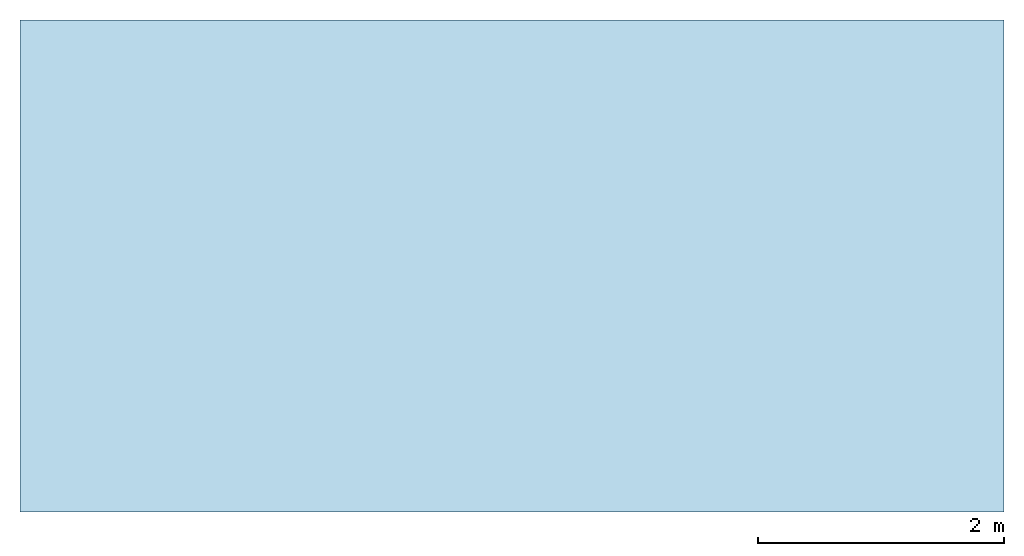
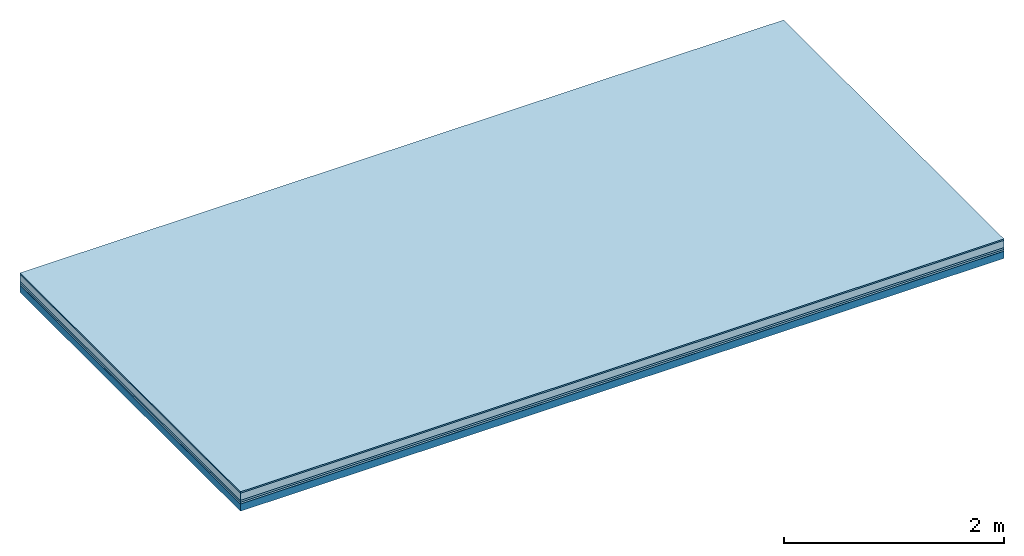
# One storey: 5 plates, 1 member, 1 element without a shape of its own.
"""IFC4 building model written with IfcOpenShell, lengths in metres."""

from ifc_helpers import new_model, si_unit, derived_unit, direction, frame, frame_2d, origin, origin_with_axes, place, context, project, spatial, rectangle, extrude, material, layer, layer_set, type_object, element, aggregate, save


model = new_model("IFC4")

# Units and contexts
plan_context = context("Plan", 3, precision=1e-05, world=origin(), true_north=direction((0.0, 1.0)))
model_context = context("Model", 3, precision=1e-05, world=origin(), true_north=direction((0.0, 1.0)))
ifc_project = project(units=[si_unit("LENGTHUNIT", "METRE"), derived_unit("SOUNDPRESSUREUNIT", [(si_unit("PRESSUREUNIT", "PASCAL", prefix="MICRO"), 0)]), si_unit("ENERGYUNIT", "JOULE", prefix="MEGA"), si_unit("MASSUNIT", "GRAM", prefix="KILO"), derived_unit("THERMALTRANSMITTANCEUNIT", [(si_unit("POWERUNIT", "WATT"), 1), (si_unit("AREAUNIT", "SQUARE_METRE"), -1), (si_unit("THERMODYNAMICTEMPERATUREUNIT", "KELVIN"), -1)]), derived_unit("AREADENSITYUNIT", [(si_unit("MASSUNIT", "GRAM", prefix="KILO"), 1), (si_unit("AREAUNIT", "SQUARE_METRE"), -1)]), derived_unit("USERDEFINED", [(si_unit("ENERGYUNIT", "JOULE", prefix="MEGA"), 1), (si_unit("AREAUNIT", "SQUARE_METRE"), -1)])], contexts=[plan_context, model_context])

# Site, building, storey
site = spatial("IfcSite", under=ifc_project)
building_placement = place(None, origin())
building = spatial("IfcBuilding", under=site, at=building_placement)
storey_placement = place(building_placement, origin())
storey = spatial("IfcBuildingStorey", under=building, at=storey_placement)

# Slab, member, plates
ifc_material_1 = material(Category="11.013")
ifc_layer_1 = layer(ifc_material_1, 0.015, Name="Flooring")
ifc_material_2 = material(Name="Cement screed", Category="04.006")
ifc_layer_2 = layer(ifc_material_2, 0.08, Name="On-material")
ifc_material_3 = material(Name="Wood fiber generic product", Category="10.009")
ifc_layer_3 = layer(ifc_material_3, 0.02, Name="Impact sound insulation")
ifc_material_4 = material()
ifc_layer_4 = layer(ifc_material_4, 0.02, Name="Additional insulation")
ifc_material_5 = material(Name="protection", Category="09.007")
ifc_layer_5 = layer(ifc_material_5, 0.0005, Name="Sub-floor")
ifc_material_6 = material(Name="no composite action")
ifc_layer_6 = layer(ifc_material_6, 0.0, Name="Bond")
ifc_layer_7 = layer(None, 0.08, Name="Supporting structure")
ifc_layer_set = layer_set([ifc_layer_1, ifc_layer_2, ifc_layer_3, ifc_layer_4, ifc_layer_5, ifc_layer_6, ifc_layer_7])
slab_type = type_object("IfcSlabType", Name="A2067", PredefinedType="NOTDEFINED", material=ifc_layer_set)
slab_placement = place(None, frame((0.0, 0.0, 0.0), z_axis=(0.0, 0.0, -1.0), x_axis=(1.0, 0.0, 0.0)))
slab = element("IfcSlab", 1, at=slab_placement, inside=storey, type_object=slab_type, material=ifc_layer_set, Name="Slab #1")
ifc_material_7 = material(Name="Solid timber panel")
member_placement = place(slab_placement, origin())
member = element("IfcMember", 2, at=member_placement, material=ifc_material_7, Name="Supporting structure", context=plan_context, shape_type="SweptSolid", body=[
    extrude(rectangle(XDim=1.0, YDim=0.08, at=frame_2d((0.5, 0.04), x_axis=(1.0, 0.0))), frame((0.0, 4.0, 0.1355), z_axis=(0.0, -1.0, 0.0), x_axis=(1.0, 0.0, 0.0)), (0.0, 0.0, 1.0), 4.0),
    extrude(rectangle(XDim=1.0, YDim=0.08, at=frame_2d((0.5, 0.04), x_axis=(1.0, 0.0))), frame((1.0, 4.0, 0.1355), z_axis=(0.0, -1.0, 0.0), x_axis=(1.0, 0.0, 0.0)), (0.0, 0.0, 1.0), 4.0),
    extrude(rectangle(XDim=1.0, YDim=0.08, at=frame_2d((0.5, 0.04), x_axis=(1.0, 0.0))), frame((2.0, 4.0, 0.1355), z_axis=(0.0, -1.0, 0.0), x_axis=(1.0, 0.0, 0.0)), (0.0, 0.0, 1.0), 4.0),
    extrude(rectangle(XDim=1.0, YDim=0.08, at=frame_2d((0.5, 0.04), x_axis=(1.0, 0.0))), frame((3.0, 4.0, 0.1355), z_axis=(0.0, -1.0, 0.0), x_axis=(1.0, 0.0, 0.0)), (0.0, 0.0, 1.0), 4.0),
    extrude(rectangle(XDim=1.0, YDim=0.08, at=frame_2d((0.5, 0.04), x_axis=(1.0, 0.0))), frame((4.0, 4.0, 0.1355), z_axis=(0.0, -1.0, 0.0), x_axis=(1.0, 0.0, 0.0)), (0.0, 0.0, 1.0), 4.0),
    extrude(rectangle(XDim=1.0, YDim=0.08, at=frame_2d((0.5, 0.04), x_axis=(1.0, 0.0))), frame((5.0, 4.0, 0.1355), z_axis=(0.0, -1.0, 0.0), x_axis=(1.0, 0.0, 0.0)), (0.0, 0.0, 1.0), 4.0),
    extrude(rectangle(XDim=1.0, YDim=0.08, at=frame_2d((0.5, 0.04), x_axis=(1.0, 0.0))), frame((6.0, 4.0, 0.1355), z_axis=(0.0, -1.0, 0.0), x_axis=(1.0, 0.0, 0.0)), (0.0, 0.0, 1.0), 4.0),
    extrude(rectangle(XDim=1.0, YDim=0.08, at=frame_2d((0.5, 0.04), x_axis=(1.0, 0.0))), frame((7.0, 4.0, 0.1355), z_axis=(0.0, -1.0, 0.0), x_axis=(1.0, 0.0, 0.0)), (0.0, 0.0, 1.0), 4.0),
])
plate_1_placement = place(slab_placement, origin())
plate_1 = element("IfcPlate", 3, at=plate_1_placement, material=ifc_material_1, Name="Flooring", context=plan_context, shape_type="SweptSolid", body=[
    extrude(rectangle(XDim=8.0, YDim=4.0, at=frame_2d((4.0, 2.0), x_axis=(1.0, 0.0))), origin_with_axes(), (0.0, 0.0, 1.0), 0.015),
])
plate_2_placement = place(slab_placement, origin())
plate_2 = element("IfcPlate", 4, at=plate_2_placement, material=ifc_material_2, Name="On-material", context=plan_context, shape_type="SweptSolid", body=[
    extrude(rectangle(XDim=8.0, YDim=4.0, at=frame_2d((4.0, 2.0), x_axis=(1.0, 0.0))), frame((0.0, 0.0, 0.015), z_axis=(0.0, 0.0, 1.0), x_axis=(1.0, 0.0, 0.0)), (0.0, 0.0, 1.0), 0.08),
])
plate_3_placement = place(slab_placement, origin())
plate_3 = element("IfcPlate", 5, at=plate_3_placement, material=ifc_material_3, Name="Impact sound insulation", context=plan_context, shape_type="SweptSolid", body=[
    extrude(rectangle(XDim=8.0, YDim=4.0, at=frame_2d((4.0, 2.0), x_axis=(1.0, 0.0))), frame((0.0, 0.0, 0.095), z_axis=(0.0, 0.0, 1.0), x_axis=(1.0, 0.0, 0.0)), (0.0, 0.0, 1.0), 0.02),
])
plate_4_placement = place(slab_placement, origin())
plate_4 = element("IfcPlate", 6, at=plate_4_placement, material=ifc_material_4, Name="Additional insulation", context=plan_context, shape_type="SweptSolid", body=[
    extrude(rectangle(XDim=8.0, YDim=4.0, at=frame_2d((4.0, 2.0), x_axis=(1.0, 0.0))), frame((0.0, 0.0, 0.115), z_axis=(0.0, 0.0, 1.0), x_axis=(1.0, 0.0, 0.0)), (0.0, 0.0, 1.0), 0.02),
])
plate_5_placement = place(slab_placement, origin())
plate_5 = element("IfcPlate", 7, at=plate_5_placement, material=ifc_material_5, Name="Sub-floor", context=plan_context, shape_type="SweptSolid", body=[
    extrude(rectangle(XDim=8.0, YDim=4.0, at=frame_2d((4.0, 2.0), x_axis=(1.0, 0.0))), frame((0.0, 0.0, 0.135), z_axis=(0.0, 0.0, 1.0), x_axis=(1.0, 0.0, 0.0)), (0.0, 0.0, 1.0), 0.0005),
])
aggregate(slab, [plate_1, plate_2, plate_3, plate_4, plate_5, member])

save(model, "model.ifc")
